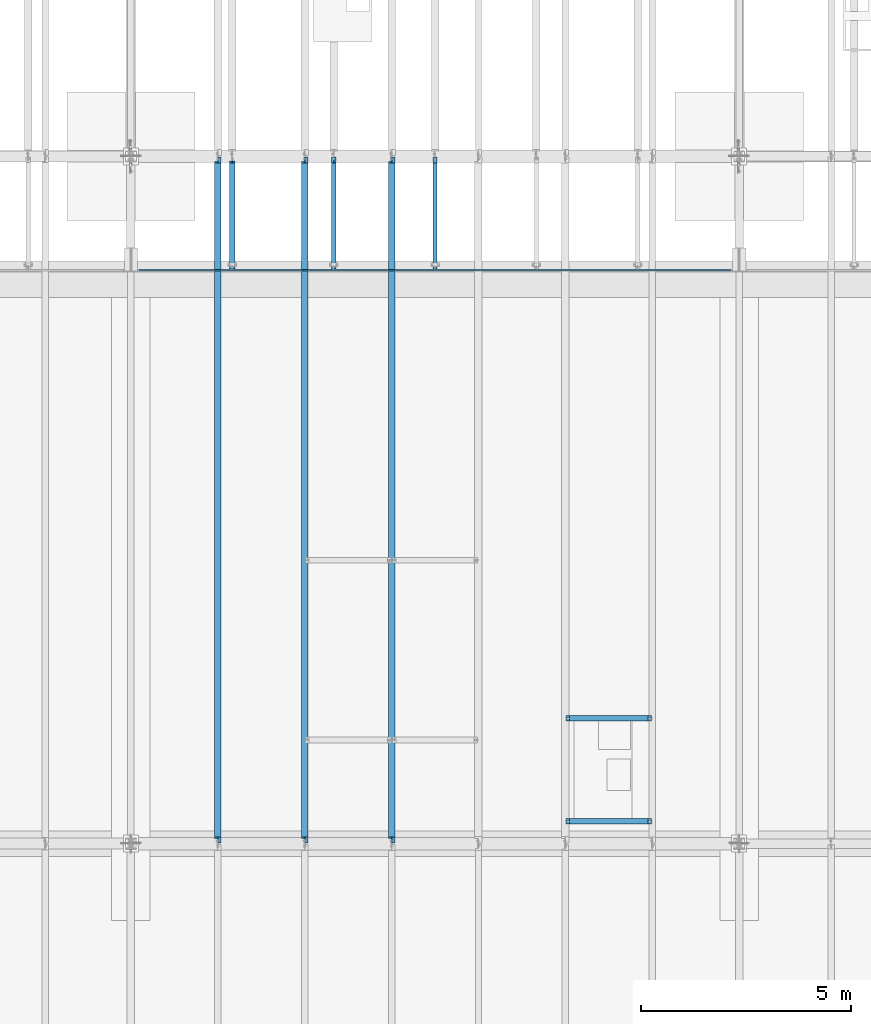
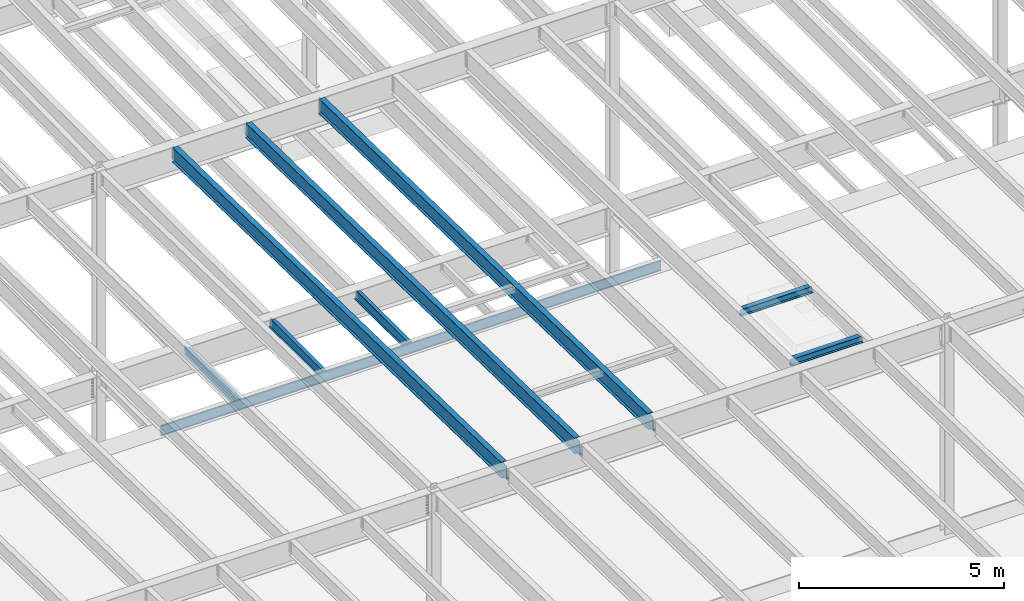
# One storey, part 1102 of 1763: 9 beams, 9 elements without a shape of their own.
"""IFC2X3 building model written with IfcOpenShell, lengths in millimetres."""

import ifcopenshell
import ifcopenshell.guid

model = None  # the IFC model being written
_history = None  # IfcOwnerHistory: only IFC2X3 demands one
_inside = {}  # id of a spatial element -> (the spatial element, [elements in it])
_under = {}  # id of a project, library or spatial element -> (it, [spatial elements below it])
_declared = {}  # id of a project -> (the project, [libraries it declares])
_typed = {}  # id of a type object -> (the type object, [elements of that type])
_made_of = {}  # id of a material, layer set ... -> (it, [elements and type objects made of it])


def new_model(schema):
    """Start an empty IFC model of exactly this schema.

    Asked for "IFC4X3", IfcOpenShell would pick the latest addendum, in which some entities
    have other attributes; the version numbers below select the first issue.
    IFC2X3 requires an IfcOwnerHistory on every rooted entity: one is made here for all.
    """
    global model, _history
    if schema == "IFC4X3":
        model = ifcopenshell.file(schema_version=(4, 3, 0, 0))
    else:
        model = ifcopenshell.file(schema=schema)
    _inside.clear()
    _under.clear()
    _declared.clear()
    _typed.clear()
    _made_of.clear()
    _history = None
    if model.schema == "IFC2X3":
        org = make("IfcOrganization", Name="unknown")
        user = make(
            "IfcPersonAndOrganization",
            ThePerson=make("IfcPerson", FamilyName="unknown"),
            TheOrganization=org,
        )
        app = make(
            "IfcApplication",
            ApplicationDeveloper=org,
            Version="unknown",
            ApplicationFullName="unknown",
            ApplicationIdentifier="unknown",
        )
        _history = make(
            "IfcOwnerHistory",
            OwningUser=user,
            OwningApplication=app,
            ChangeAction="ADDED",
            CreationDate=0,
        )
    return model


def make(cls, **values):
    """One entity of the class cls with the attributes given. An attribute that is None is left unset."""
    return model.create_entity(
        cls, **{name: value for name, value in values.items() if value is not None}
    )


def rooted(cls, **values):
    """An entity with a GlobalId (a new one), such as an element, a storey or a relation."""
    return make(cls, GlobalId=ifcopenshell.guid.new(), OwnerHistory=_history, **values)


def si_unit(unit_type, name, prefix=None):
    """IfcSIUnit, for example si_unit("LENGTHUNIT", "METRE", prefix="MILLI")."""
    return make("IfcSIUnit", UnitType=unit_type, Prefix=prefix, Name=name)


def assignment(units):
    """IfcUnitAssignment: the units of a project."""
    return None if units is None else make("IfcUnitAssignment", Units=units)


def point(xyz):
    """IfcCartesianPoint."""
    return None if xyz is None else make("IfcCartesianPoint", Coordinates=xyz)


def direction(xyz):
    """IfcDirection."""
    return None if xyz is None else make("IfcDirection", DirectionRatios=xyz)


def frame(location, z_axis=None, x_axis=None):
    """IfcAxis2Placement3D, a coordinate frame: its origin and axes. An axis left out is left unset."""
    return make(
        "IfcAxis2Placement3D",
        Location=point(location),
        Axis=direction(z_axis),
        RefDirection=direction(x_axis),
    )


def origin_with_axes():
    """The frame at (0, 0, 0) with the z axis (0, 0, 1) and the x axis (1, 0, 0) written out."""
    return frame((0.0, 0.0, 0.0), z_axis=(0.0, 0.0, 1.0), x_axis=(1.0, 0.0, 0.0))


def place(relative_to, where):
    """IfcLocalPlacement: puts the frame where relative to a parent placement (None: the world)."""
    return make(
        "IfcLocalPlacement", PlacementRelTo=relative_to, RelativePlacement=where
    )


def context(
    kind, dimensions, precision=None, world=None, true_north=None, identifier=None
):
    """IfcGeometricRepresentationContext, for example the 3D "Model" context."""
    return make(
        "IfcGeometricRepresentationContext",
        ContextIdentifier=identifier,
        ContextType=kind,
        CoordinateSpaceDimension=dimensions,
        Precision=precision,
        WorldCoordinateSystem=world,
        TrueNorth=true_north,
    )


def subcontext(parent, identifier, kind, view, scale=None):
    """IfcGeometricRepresentationSubContext, for example "Body" below "Model"."""
    return make(
        "IfcGeometricRepresentationSubContext",
        ContextIdentifier=identifier,
        ContextType=kind,
        ParentContext=parent,
        TargetScale=scale,
        TargetView=view,
    )


def project(units=None, contexts=None):
    """IfcProject with its units and contexts."""
    return rooted(
        "IfcProject",
        Name="project",
        RepresentationContexts=contexts,
        UnitsInContext=assignment(units),
    )


def spatial(cls, under=None, at=None, **own):
    """A site, building, storey or space (cls), placed at a placement, below another one or the project."""
    s = rooted(cls, ObjectPlacement=at, **own)
    if under is not None:
        _under.setdefault(under.id(), (under, []))[1].append(s)
    return s


def faces_of(points, faces, orient=None, outer=None):
    """IfcFace entities. A face is a list of loops; a loop is a list of indices into points, from 0.

    orient and outer hold one flag for each loop. By default every Orientation is true, the
    first loop of a face is its IfcFaceOuterBound and the others are IfcFaceBound.
    """
    made = []
    for i, loops in enumerate(faces):
        bounds = []
        for j, loop in enumerate(loops):
            is_outer = j == 0 if outer is None else outer[i][j]
            bounds.append(
                make(
                    "IfcFaceOuterBound" if is_outer else "IfcFaceBound",
                    Bound=make("IfcPolyLoop", Polygon=[points[k] for k in loop]),
                    Orientation=True if orient is None else orient[i][j],
                )
            )
        made.append(make("IfcFace", Bounds=bounds))
    return made


def faceted_brep(points, faces, orient=None, outer=None, voids=None):
    """IfcFacetedBrep: a solid bounded by flat faces; with voids (closed shells), ...WithVoids."""
    shared = [point(p) for p in points]
    hull = make("IfcClosedShell", CfsFaces=faces_of(shared, faces, orient, outer))
    if voids is None:
        return make("IfcFacetedBrep", Outer=hull)
    return make(
        "IfcFacetedBrepWithVoids",
        Outer=hull,
        Voids=[
            make(cls, CfsFaces=faces_of(shared, fs, o, b)) for cls, fs, o, b in voids
        ],
    )


def shape(context_of_items, identifier, shape_type, items):
    """IfcShapeRepresentation: the items that make up one representation, for example the "Body"."""
    return make(
        "IfcShapeRepresentation",
        ContextOfItems=context_of_items,
        RepresentationIdentifier=identifier,
        RepresentationType=shape_type,
        Items=items,
    )


def material(Name=None, Category=None):
    """IfcMaterial."""
    return make("IfcMaterial", Name=Name, Category=Category)


def made_of(thing, what):
    """Note that an element or type object is made of a material, layer set ...; save() writes the relation."""
    if what is not None:
        _made_of.setdefault(what.id(), (what, []))[1].append(thing)
    return thing


def type_object(cls, material=None, **own):
    """A type object (cls), such as IfcWallType, which elements share."""
    return made_of(rooted(cls, **own), material)


def element(
    cls,
    number,
    at=None,
    inside=None,
    cuts=None,
    type_object=None,
    material=None,
    context=None,
    identifier="Body",
    shape_type=None,
    held_by="IfcProductDefinitionShape",
    body=None,
    shapes=None,
    **own,
):
    """One element of the class cls, such as IfcWall. Its Tag is "e" and its number.

    at: its placement. inside: the storey or other place that contains it. cuts: it is an
    opening in that element (IfcRelVoidsElement). A single representation is given by context,
    identifier, shape_type and body (its items); several are given by shapes. held_by: the class
    of the entity that holds the representations. save() writes the other relations.
    """
    e = rooted(cls, Tag="e%d" % number, ObjectPlacement=at, **own)
    if body is not None:
        shapes = [shape(context, identifier, shape_type, body)]
    if shapes is not None:
        e.Representation = make(held_by, Representations=shapes)
    if inside is not None:
        _inside.setdefault(inside.id(), (inside, []))[1].append(e)
    if cuts is not None:
        rooted(
            "IfcRelVoidsElement", RelatingBuildingElement=cuts, RelatedOpeningElement=e
        )
    if type_object is not None:
        _typed.setdefault(type_object.id(), (type_object, []))[1].append(e)
    return made_of(e, material)


def aggregate(whole, parts):
    """IfcRelAggregates: a whole, such as a stair, and the parts it consists of."""
    return rooted("IfcRelAggregates", RelatingObject=whole, RelatedObjects=parts)


def save(model, path):
    """Write the relations noted so far, then the file.

    IfcRelAggregates (storeys below a building ...), IfcRelContainedInSpatialStructure (elements
    in a storey), IfcRelDefinesByType, IfcRelAssociatesMaterial and IfcRelDeclares: one each for
    every whole, place, type object, material and project.
    """
    for whole, parts in _under.values():
        aggregate(whole, parts)
    for where, things in _inside.values():
        rooted(
            "IfcRelContainedInSpatialStructure",
            RelatedElements=things,
            RelatingStructure=where,
        )
    for kind, things in _typed.values():
        rooted("IfcRelDefinesByType", RelatedObjects=things, RelatingType=kind)
    for what, things in _made_of.values():
        rooted("IfcRelAssociatesMaterial", RelatedObjects=things, RelatingMaterial=what)
    for by, libraries in _declared.values():
        rooted("IfcRelDeclares", RelatingContext=by, RelatedDefinitions=libraries)
    model.write(path)


model = new_model("IFC2X3")

# Units and contexts
model_context = context("Model", 3, precision=1e-05, world=origin_with_axes())
body_context = subcontext(model_context, "Body", "Model", "MODEL_VIEW")
ifc_project = project(units=[si_unit("LENGTHUNIT", "METRE", prefix="MILLI"), si_unit("AREAUNIT", "SQUARE_METRE"), si_unit("VOLUMEUNIT", "CUBIC_METRE"), si_unit("MASSUNIT", "GRAM", prefix="KILO"), si_unit("TIMEUNIT", "SECOND"), si_unit("PLANEANGLEUNIT", "RADIAN"), si_unit("SOLIDANGLEUNIT", "STERADIAN"), si_unit("THERMODYNAMICTEMPERATUREUNIT", "DEGREE_CELSIUS"), si_unit("LUMINOUSINTENSITYUNIT", "LUMEN")], contexts=[model_context])

# Site, building, storey
site_placement = place(None, origin_with_axes())
site = spatial("IfcSite", under=ifc_project, at=site_placement, CompositionType="ELEMENT")
building_placement = place(site_placement, origin_with_axes())
building = spatial("IfcBuilding", under=site, at=building_placement, Name="Undefined", CompositionType="ELEMENT")
storey_placement = place(building_placement, origin_with_axes())
storey = spatial("IfcBuildingStorey", under=building, at=storey_placement, Name="Undefined", CompositionType="ELEMENT", Elevation=0.0)

# Assembly, beam
assembly_1_placement = place(storey_placement, origin_with_axes())
assembly_1 = element("IfcElementAssembly", 1, at=assembly_1_placement, inside=storey, Name="BEAM", AssemblyPlace="NOTDEFINED", PredefinedType="RIGID_FRAME")
ifc_material = material(Name="STEEL/A992")
beam_type_1 = type_object("IfcBeamType", Name="W8X18", PredefinedType="NOTDEFINED")
beam_1_placement = place(assembly_1_placement, frame((-39079.0948629841, 14224.0000000266, 11477.0442138004), z_axis=(0.0, 0.0, 1.0), x_axis=(1.0, 0.0, 0.0)))
beam_1 = element("IfcBeam", 2, at=beam_1_placement, type_object=beam_type_1, material=ifc_material, Name="BEAM", ObjectType="W8X18", context=body_context, shape_type="Brep", body=[
    faceted_brep([(87.2558037621566, -3.17499999999927, 64.8275016696698), (87.2558037621566, 3.17499999999927, 64.8275016696698), (17.4058035714115, 3.17499999999927, 64.8275016696698), (17.4058035714115, -3.17499999999927, 64.8275016696698), (92.115883280203, -3.17499999999927, 65.7942315922573), (92.115883280203, 3.17499999999927, 65.7942315922573), (96.2360597483566, -3.17499999999927, 68.5472454927349), (96.2360597483566, 3.17499999999927, 68.5472454927349), (98.9890736488305, -3.17499999999927, 72.6674219608885), (98.9890736488305, 3.17499999999927, 72.6674219608885), (99.9558035714217, -3.17499999999927, 77.5275014789349), (99.9558035714217, 3.17499999999927, 77.5275014789349), (99.9558035714217, -66.6749999999993, 103.1875), (99.9558035714217, 66.6749999999993, 103.1875), (99.9558035714217, 66.6749999999993, 95.25), (99.9558035714217, 3.17499999999927, 95.25), (99.9558035714217, -3.17499999999927, 95.25), (99.9558035714217, -66.6749999999993, 95.25), (17.4058035714115, -3.17499999999927, -95.25), (17.4058035714115, -66.6749999999993, -95.25), (2047.93169642858, -66.6749999999993, -95.25), (2047.93169642858, -3.17499999999927, -95.25), (17.4058035714115, -66.6749999999993, -103.1875), (2047.93169642858, -66.6749999999993, -103.1875), (17.4058035714115, 66.6749999999993, -103.1875), (2047.93169642858, 66.6749999999993, -103.1875), (17.4058035714115, 66.6749999999993, -95.25), (2047.93169642858, 66.6749999999993, -95.25), (17.4058035714115, 3.17499999999927, -95.25), (2047.93169642858, 3.17499999999927, -95.25), (2047.93169642858, 3.17499999999927, 64.8275016697553), (2047.93169642858, -3.17499999999927, 64.8275016697553), (1978.08169623784, 3.17499999999927, 64.8275016697553), (1978.08169623784, -3.17499999999927, 64.8275016697553), (1973.2216167198, 3.17499999999927, 65.7942315923428), (1973.2216167198, -3.17499999999927, 65.7942315923428), (1969.10144025164, 3.17499999999927, 68.5472454928204), (1969.10144025164, -3.17499999999927, 68.5472454928204), (1966.34842635117, 3.17499999999927, 72.667421960974), (1966.34842635117, -3.17499999999927, 72.667421960974), (1965.38169642858, 3.17499999999927, 77.5275014790204), (1965.38169642858, -3.17499999999927, 77.5275014790204), (1965.38169642858, -66.6749999999993, 103.1875), (1965.38169642858, -66.6749999999993, 95.25), (1965.38169642858, -3.17499999999927, 95.25), (1965.38169642858, 3.17499999999927, 95.25), (1965.38169642858, 66.6749999999993, 95.25), (1965.38169642858, 66.6749999999993, 103.1875)], [[[0, 1, 2, 3]], [[4, 5, 1, 0]], [[6, 7, 5, 4]], [[8, 9, 7, 6]], [[10, 11, 9, 8]], [[12, 13, 14, 15, 11, 10, 16, 17]], [[18, 19, 20, 21]], [[19, 22, 23, 20]], [[22, 24, 25, 23]], [[24, 26, 27, 25]], [[26, 28, 29, 27]], [[21, 20, 23, 25, 27, 29, 30, 31]], [[31, 30, 32, 33]], [[33, 32, 34, 35]], [[35, 34, 36, 37]], [[37, 36, 38, 39]], [[39, 38, 40, 41]], [[42, 43, 44, 41, 40, 45, 46, 47]], [[43, 42, 12, 17]], [[44, 43, 17, 16]], [[8, 6, 4, 0, 3, 18, 21, 31, 33, 35, 37, 39, 41, 44, 16, 10]], [[28, 26, 24, 22, 19, 18, 3, 2]], [[45, 40, 38, 36, 34, 32, 30, 29, 28, 2, 1, 5, 7, 9, 11, 15]], [[46, 45, 15, 14]], [[47, 46, 14, 13]], [[42, 47, 13, 12]]]),
])
aggregate(assembly_1, [beam_1])

assembly_2_placement = place(storey_placement, origin_with_axes())
assembly_2 = element("IfcElementAssembly", 3, at=assembly_2_placement, inside=storey, Name="BEAM", AssemblyPlace="NOTDEFINED", PredefinedType="RIGID_FRAME")
beam_2_placement = place(assembly_2_placement, frame((-39079.0948629841, 16668.7500000266, 11477.0442138004), z_axis=(0.0, 0.0, 1.0), x_axis=(1.0, 0.0, 0.0)))
beam_2 = element("IfcBeam", 4, at=beam_2_placement, type_object=beam_type_1, material=ifc_material, Name="BEAM", ObjectType="W8X18", context=body_context, shape_type="Brep", body=[
    faceted_brep([(17.4058035714115, -3.17499999999927, -95.25), (17.4058035714115, -66.6749999999993, -95.25), (2047.93169642858, -66.6749999999993, -95.25), (2047.93169642858, -3.17499999999927, -95.25), (17.4058035714115, -66.6749999999993, -103.1875), (2047.93169642858, -66.6749999999993, -103.1875), (17.4058035714115, 66.6749999999993, -103.1875), (2047.93169642858, 66.6749999999993, -103.1875), (17.4058035714115, 66.6749999999993, -95.25), (2047.93169642858, 66.6749999999993, -95.25), (1965.38169642858, -66.6749999999993, 103.1875), (1965.38169642858, -66.6749999999993, 95.25), (1965.38169642858, -3.17499999999927, 95.25), (1965.38169642858, -3.17499999999927, 77.5275014790204), (1965.38169642858, 3.17499999999927, 77.5275014790204), (1965.38169642858, 3.17499999999927, 95.25), (1965.38169642858, 66.6749999999993, 95.25), (1965.38169642858, 66.6749999999993, 103.1875), (1966.34842635117, -3.17499999999927, 72.667421960974), (1966.34842635117, 3.17499999999927, 72.667421960974), (1969.10144025164, -3.17499999999927, 68.5472454928204), (1969.10144025164, 3.17499999999927, 68.5472454928204), (1973.2216167198, -3.17499999999927, 65.7942315923428), (1973.2216167198, 3.17499999999927, 65.7942315923428), (1978.08169623784, -3.17499999999927, 64.8275016697553), (1978.08169623784, 3.17499999999927, 64.8275016697553), (1981.05345884623, -3.17499999999927, 64.8275016740627), (1981.05345884623, 3.17499999999927, 64.8275016740627), (1983.54036977155, -3.17499999999927, 63.1658009193525), (1983.54036977155, 3.17499999999927, 63.1658009193525), (1988.4004492896, -3.17499999999927, 62.1990709967649), (1988.4004492896, 3.17499999999927, 62.1990709967649), (2047.93169642858, -3.17499999999927, 62.1990709967649), (2047.93169642858, 3.17499999999927, 62.1990709967649), (2047.93169642858, 3.17499999999927, -95.25), (17.4058035714115, 3.17499999999927, -95.25), (93.703380228435, -3.17499999999927, 56.8144134123104), (93.703380228435, 3.17499999999927, 56.8144134123104), (88.8433007103886, 3.17499999999927, 55.8476834897228), (88.8433007103886, -3.17499999999927, 55.8476834897228), (97.8235566965886, -3.17499999999927, 59.5674273127879), (97.8235566965886, 3.17499999999927, 59.5674273127879), (100.576570597063, -3.17499999999927, 63.6876037809416), (100.576570597063, 3.17499999999927, 63.6876037809416), (101.543300519654, -3.17499999999927, 68.547683298988), (101.543300519654, 3.17499999999927, 68.547683298988), (17.4058035714115, 3.17499999999927, 55.8476834897228), (101.543300519654, 3.17499999999927, 95.25), (101.543300519654, 66.6749999999993, 95.25), (101.543300519654, 66.6749999999993, 103.1875), (101.543300519654, -66.6749999999993, 103.1875), (101.543300519654, -66.6749999999993, 95.25), (101.543300519654, -3.17499999999927, 95.25), (17.4058035714115, -3.17499999999927, 55.8476834897228)], [[[0, 1, 2, 3]], [[1, 4, 5, 2]], [[4, 6, 7, 5]], [[6, 8, 9, 7]], [[10, 11, 12, 13, 14, 15, 16, 17]], [[18, 19, 14, 13]], [[20, 21, 19, 18]], [[22, 23, 21, 20]], [[24, 25, 23, 22]], [[26, 27, 25, 24]], [[28, 29, 27, 26]], [[30, 31, 29, 28]], [[32, 33, 31, 30]], [[3, 2, 5, 7, 9, 34, 33, 32]], [[8, 35, 34, 9]], [[36, 37, 38, 39]], [[40, 41, 37, 36]], [[42, 43, 41, 40]], [[44, 45, 43, 42]], [[15, 14, 19, 21, 23, 25, 27, 29, 31, 33, 34, 35, 46, 38, 37, 41, 43, 45, 47]], [[16, 15, 47, 48]], [[17, 16, 48, 49]], [[10, 17, 49, 50]], [[11, 10, 50, 51]], [[12, 11, 51, 52]], [[50, 49, 48, 47, 45, 44, 52, 51]], [[42, 40, 36, 39, 53, 0, 3, 32, 30, 28, 26, 24, 22, 20, 18, 13, 12, 52, 44]], [[35, 8, 6, 4, 1, 0, 53, 46]], [[39, 38, 46, 53]]]),
])
aggregate(assembly_2, [beam_2])

assembly_3_placement = place(storey_placement, origin_with_axes())
assembly_3 = element("IfcElementAssembly", 5, at=assembly_3_placement, inside=storey, Name="BEAM", AssemblyPlace="NOTDEFINED", PredefinedType="RIGID_FRAME")
beam_3_placement = place(assembly_3_placement, frame((-46993.6706070317, 27279.6, 5091.1125), z_axis=(0.0, 0.0, 1.0), x_axis=(0.0, 1.0, 0.0)))
beam_3 = element("IfcBeam", 6, at=beam_3_placement, type_object=beam_type_1, material=ifc_material, Name="BEAM", ObjectType="W8X18", context=body_context, shape_type="Brep", body=[
    faceted_brep([(2634.45622848038, 3.4751352359599, -95.25), (2634.45622848058, 3.47487102042214, -103.1875), (2634.45618089067, 66.6750000000029, -103.1875), (2634.45618089067, 66.6750000000029, -95.25), (2723.35625, 3.47520217805868, -95.25), (2723.35625, 3.47493796249182, -103.1875), (63.5000000000036, 3.17500000000291, 95.25), (63.5000000000036, 66.6750000000029, 95.25), (2583.65625, 66.6750000000029, 95.25), (2583.65625, 3.17500000000291, 95.25), (63.5000000000036, -66.6750000000029, -103.1875), (63.5000000000036, -66.6750000000029, -95.25), (63.5000000000036, -3.17500000000291, -95.25), (63.5000000000036, -3.17500000000291, 95.25), (63.5000000000036, -66.6750000000029, 95.25), (63.5000000000036, -66.6750000000029, 103.1875), (63.5000000000036, 66.6750000000029, 103.1875), (63.5000000000036, 3.17500000000291, -95.25), (63.5000000000036, 66.6750000000029, -95.25), (63.5000000000036, 66.6750000000029, -103.1875), (2634.45624623523, -66.6750000000029, -103.1875), (2634.45624623523, -66.6750000000029, -95.25), (2634.45619864566, -3.47513512033038, -103.1875), (2634.45619864546, -3.47487090479262, -95.25), (2723.35625, -3.47480396302853, -95.25), (2723.35625, -3.47506817859539, -103.1875), (2723.35625, -3.17500000000291, -95.25), (2591.49617029122, -3.17500000000291, 72.1442316010543), (2587.37599382306, -3.17500000000291, 74.8972455015328), (2584.62297992258, -3.17500000000291, 79.0174219696864), (2583.65625, -3.17500000000291, 83.8775014877319), (2583.65625, -3.17500000000291, 95.25), (2723.35625, -3.17500000000291, 71.1775016784668), (2596.35624980926, -3.17500000000291, 71.1775016784668), (2583.65625, -66.6750000000029, 95.25), (2583.65625, -66.6750000000029, 103.1875), (2583.65625, 66.6750000000029, 103.1875), (2583.65625, 3.17500000000291, 83.8775014877319), (2584.62297992258, 3.17500000000291, 79.0174219696864), (2587.37599382306, 3.17500000000291, 74.8972455015328), (2591.49617029122, 3.17500000000291, 72.1442316010543), (2596.35624980926, 3.17500000000291, 71.1775016784668), (2723.35625, 3.17500000000291, 71.1775016784668), (2723.35625, 3.17500000000291, -95.25)], [[[0, 1, 2, 3]], [[4, 5, 1, 0]], [[6, 7, 8, 9]], [[10, 11, 12, 13, 14, 15, 16, 7, 6, 17, 18, 19]], [[11, 10, 20, 21]], [[21, 20, 22, 23]], [[24, 23, 22, 25]], [[26, 12, 11, 21, 23, 24]], [[27, 28, 29, 30, 31, 13, 12, 26, 32, 33]], [[14, 13, 31, 34]], [[15, 14, 34, 35]], [[16, 15, 35, 36]], [[7, 16, 36, 8]], [[35, 34, 31, 30, 37, 9, 8, 36]], [[29, 38, 37, 30]], [[28, 39, 38, 29]], [[27, 40, 39, 28]], [[33, 41, 40, 27]], [[32, 42, 41, 33]], [[43, 17, 6, 9, 37, 38, 39, 40, 41, 42]], [[3, 18, 17, 43, 4, 0]], [[19, 18, 3, 2]], [[25, 22, 20, 10, 19, 2, 1, 5]], [[43, 42, 32, 26, 24, 25, 5, 4]]]),
])
aggregate(assembly_3, [beam_3])

assembly_4_placement = place(storey_placement, origin_with_axes())
assembly_4 = element("IfcElementAssembly", 7, at=assembly_4_placement, inside=storey, Name="BEAM", AssemblyPlace="NOTDEFINED", PredefinedType="RIGID_FRAME")
beam_type_2 = type_object("IfcBeamType", Name="W12X16", PredefinedType="NOTDEFINED")
beam_4_placement = place(assembly_4_placement, frame((-42176.1372736983, 27279.6, 5041.9), z_axis=(0.0, 0.0, 1.0), x_axis=(0.0, 1.0, 0.0)))
beam_4 = element("IfcBeam", 8, at=beam_4_placement, type_object=beam_type_2, material=ifc_material, Name="BEAM", ObjectType="W12X16", context=body_context, shape_type="Brep", body=[
    faceted_brep([(63.5000000000036, -3.17499999999927, -146.05), (63.5000000000036, -50.7999999999993, -146.05), (2723.35625, -50.8000000000029, -146.05), (2723.35625, -3.17500000000291, -146.05), (63.5000000000036, -50.7999999999993, -152.4), (2723.35625, -50.8000000000029, -152.4), (63.5000000000036, 50.7999999999993, -152.4), (2723.35625, 50.8000000000029, -152.4), (63.5000000000036, 50.7999999999993, -146.05), (63.5000000000036, 3.17499999999927, -146.05), (2723.35625, 3.17500000000291, -146.05), (2723.35625, 50.8000000000029, -146.05), (2723.35625, 3.17500000000291, 120.390001678466), (2723.35625, -3.17500000000291, 120.390001678466), (63.5000000000036, -3.17499999999927, 146.05), (63.5000000000036, -50.7999999999993, 146.05), (63.5000000000036, -50.7999999999993, 152.4), (63.5000000000036, 50.7999999999993, 152.4), (63.5000000000036, 50.7999999999993, 146.05), (63.5000000000036, 3.17499999999927, 146.05), (2583.65625, 50.8000000000029, 146.05), (2583.65625, 3.17500000000291, 146.05), (2583.65625, 3.17500000000291, 133.090001487732), (2584.62297992259, 3.17500000000291, 128.229921969686), (2587.37599382307, 3.17500000000291, 124.109745501532), (2591.49617029122, 3.17500000000291, 121.356731601054), (2596.35624980927, 3.17500000000291, 120.390001678466), (2584.62297992259, -3.17500000000291, 128.229921969686), (2583.65625, -3.17500000000291, 133.090001487732), (2587.37599382307, -3.17500000000291, 124.109745501532), (2591.49617029122, -3.17500000000291, 121.356731601054), (2596.35624980927, -3.17500000000291, 120.390001678466), (2583.65625, -3.17500000000291, 146.05), (2583.65625, -50.8000000000029, 146.05), (2583.65625, -50.8000000000029, 152.4), (2583.65625, 50.8000000000029, 152.4)], [[[0, 1, 2, 3]], [[1, 4, 5, 2]], [[4, 6, 7, 5]], [[8, 9, 10, 11]], [[3, 2, 5, 7, 11, 10, 12, 13]], [[6, 8, 11, 7]], [[4, 1, 0, 14, 15, 16, 17, 18, 19, 9, 8, 6]], [[19, 18, 20, 21]], [[10, 9, 19, 21, 22, 23, 24, 25, 26, 12]], [[27, 23, 22, 28]], [[29, 24, 23, 27]], [[30, 25, 24, 29]], [[31, 26, 25, 30]], [[13, 12, 26, 31]], [[30, 29, 27, 28, 32, 14, 0, 3, 13, 31]], [[15, 14, 32, 33]], [[16, 15, 33, 34]], [[17, 16, 34, 35]], [[18, 17, 35, 20]], [[34, 33, 32, 28, 22, 21, 20, 35]]]),
])
aggregate(assembly_4, [beam_4])

assembly_5_placement = place(storey_placement, origin_with_axes())
assembly_5 = element("IfcElementAssembly", 9, at=assembly_5_placement, inside=storey, Name="BEAM", AssemblyPlace="NOTDEFINED", PredefinedType="RIGID_FRAME")
beam_5_placement = place(assembly_5_placement, frame((-44584.903940365, 27279.6, 5041.9), z_axis=(0.0, 0.0, 1.0), x_axis=(0.0, 1.0, 0.0)))
beam_5 = element("IfcBeam", 10, at=beam_5_placement, type_object=beam_type_2, material=ifc_material, Name="BEAM", ObjectType="W12X16", context=body_context, shape_type="Brep", body=[
    faceted_brep([(63.5000000000036, -3.17499999999927, -146.05), (63.5000000000036, -50.7999999999993, -146.05), (2723.35625, -50.8000000000029, -146.05), (2723.35625, -3.17500000000291, -146.05), (63.5000000000036, -50.7999999999993, -152.4), (2723.35625, -50.8000000000029, -152.4), (63.5000000000036, 50.7999999999993, -152.4), (2723.35625, 50.8000000000029, -152.4), (63.5000000000036, 50.7999999999993, -146.05), (63.5000000000036, 3.17499999999927, -146.05), (2723.35625, 3.17500000000291, -146.05), (2723.35625, 50.8000000000029, -146.05), (2723.35625, 3.17500000000291, 120.390001678466), (2723.35625, -3.17500000000291, 120.390001678466), (63.5000000000036, -3.17499999999927, 146.05), (63.5000000000036, -50.7999999999993, 146.05), (63.5000000000036, -50.7999999999993, 152.4), (63.5000000000036, 50.7999999999993, 152.4), (63.5000000000036, 50.7999999999993, 146.05), (63.5000000000036, 3.17499999999927, 146.05), (2583.65625, 50.8000000000029, 146.05), (2583.65625, 3.17500000000291, 146.05), (2583.65625, 3.17500000000291, 133.090001487732), (2584.62297992259, 3.17500000000291, 128.229921969686), (2587.37599382307, 3.17500000000291, 124.109745501532), (2591.49617029122, 3.17500000000291, 121.356731601054), (2596.35624980927, 3.17500000000291, 120.390001678466), (2584.62297992259, -3.17500000000291, 128.229921969686), (2583.65625, -3.17500000000291, 133.090001487732), (2587.37599382307, -3.17500000000291, 124.109745501532), (2591.49617029122, -3.17500000000291, 121.356731601054), (2596.35624980927, -3.17500000000291, 120.390001678466), (2583.65625, -3.17500000000291, 146.05), (2583.65625, -50.8000000000029, 146.05), (2583.65625, -50.8000000000029, 152.4), (2583.65625, 50.8000000000029, 152.4)], [[[0, 1, 2, 3]], [[1, 4, 5, 2]], [[4, 6, 7, 5]], [[8, 9, 10, 11]], [[3, 2, 5, 7, 11, 10, 12, 13]], [[6, 8, 11, 7]], [[4, 1, 0, 14, 15, 16, 17, 18, 19, 9, 8, 6]], [[19, 18, 20, 21]], [[10, 9, 19, 21, 22, 23, 24, 25, 26, 12]], [[27, 23, 22, 28]], [[29, 24, 23, 27]], [[30, 25, 24, 29]], [[31, 26, 25, 30]], [[13, 12, 26, 31]], [[30, 29, 27, 28, 32, 14, 0, 3, 13, 31]], [[15, 14, 32, 33]], [[16, 15, 33, 34]], [[17, 16, 34, 35]], [[18, 17, 35, 20]], [[34, 33, 32, 28, 22, 21, 20, 35]]]),
])
aggregate(assembly_5, [beam_5])

assembly_6_placement = place(storey_placement, origin_with_axes())
assembly_6 = element("IfcElementAssembly", 11, at=assembly_6_placement, inside=storey, Name="BEAM", AssemblyPlace="NOTDEFINED", PredefinedType="RIGID_FRAME")
beam_type_3 = type_object("IfcBeamType", Name="W18X40", PredefinedType="NOTDEFINED")
beam_6_placement = place(assembly_6_placement, frame((-43208.4658451269, 13685.8551307139, 11404.7768219843), z_axis=(0.0, 0.0209013539966291, 0.999781542838788), x_axis=(0.0, 0.999781542776098, -0.0209013569953182)))
beam_6 = element("IfcBeam", 12, at=beam_6_placement, type_object=beam_type_3, material=ifc_material, Name="BEAM", ObjectType="W18X40", context=body_context, shape_type="Brep", body=[
    faceted_brep([(16224.7811528147, 3.96875, -214.312499990414), (16224.7811528147, 3.96875, -227.012499990411), (16224.7811528147, 76.1999999999971, -227.012499990411), (16224.7811528147, 76.1999999999971, -214.312499990414), (16325.4123927121, 3.96875, -227.012499990353), (16325.1468877506, 3.96875, -214.312499990354), (29.0743924101943, -3.96875, -214.31250000018), (29.0743924101943, -76.1999999999971, -214.31250000018), (16325.1468877506, -76.1999999999971, -214.312499990354), (16325.1468877506, -3.96875, -214.312499990354), (163.327262094397, -3.96875, 190.142421969791), (160.574248193921, -3.96875, 186.022245501637), (156.454071725771, -3.96875, 183.269231601158), (151.593992207727, -3.96875, 182.302501678567), (20.7827897637508, -3.96875, 182.30250167849), (16316.7225317559, -3.96875, 188.65250182258), (16188.8431415337, -3.96875, 188.652501822504), (16183.9830620156, -3.96875, 189.619231745088), (16179.8628855475, -3.96875, 192.372245645562), (16177.109871647, -3.96875, 196.492422113712), (16176.1431417244, -3.96875, 201.352501631756), (16176.1431417244, -3.96875, 214.312500009495), (164.29399201697, -3.96875, 214.312500000067), (164.293992016979, -3.96875, 195.002501487832), (164.293992016979, 3.96875, 195.002501487832), (163.327262094397, 3.96875, 190.142421969791), (160.574248193921, 3.96875, 186.022245501637), (156.454071725771, 3.96875, 183.269231601158), (151.593992207727, 3.96875, 182.302501678567), (20.7827897637508, 3.96875, 182.30250167849), (132.543992672528, 76.1999999999971, -214.312499999889), (132.543992672539, 76.1999999999971, -227.012499999888), (132.544002095599, 4.26882839031896, -227.012499999888), (132.544002095614, 4.26866853534011, -214.312499999889), (29.339897632873, 4.26882972748717, -227.01250000019), (29.0743924101943, 4.26863241521642, -214.31250000018), (29.339897632873, -76.1999999999971, -227.01250000019), (29.0743924101943, 3.96875, -214.31250000018), (16325.412392986, -76.1999999999971, -227.012499990351), (16324.7486296237, 3.96875, -195.26249999026), (16316.7225317559, 3.96875, 188.65250182258), (16188.8431415337, 3.96875, 188.652501822504), (16183.9830620156, 3.96875, 189.619231745088), (16179.8628855475, 3.96875, 192.372245645562), (16177.109871647, 3.96875, 196.492422113712), (16176.1431417244, 3.96875, 201.352501631756), (16176.1431417244, -76.1999999999971, 227.012500009492), (16176.1431417244, -76.1999999999971, 214.312500009495), (16176.1431417244, 3.96875, 214.312500009495), (16176.1431417244, 76.1999999999971, 214.312500009495), (16176.1431417244, 76.1999999999971, 227.012500009492), (164.29399201697, 3.96875, 214.312500000067), (164.29399201697, 76.1999999999971, 214.312500000067), (164.293992016963, 76.1999999999971, 227.012500000064), (164.293992016963, -76.1999999999971, 227.012500000064), (164.29399201697, -76.1999999999971, 214.312500000067)], [[[0, 1, 2, 3]], [[4, 1, 0, 5]], [[6, 7, 8, 9]], [[10, 11, 12, 13, 14, 6, 9, 15, 16, 17, 18, 19, 20, 21, 22, 23]], [[23, 24, 25, 10]], [[10, 25, 26, 11]], [[11, 26, 27, 12]], [[12, 27, 28, 13]], [[13, 28, 29, 14]], [[30, 31, 32, 33]], [[33, 32, 34, 35]], [[36, 7, 6, 14, 29, 37, 35, 34]], [[7, 36, 38, 8]], [[39, 40, 15, 9, 8, 38, 4, 5]], [[15, 40, 41, 16]], [[16, 41, 42, 17]], [[17, 42, 43, 18]], [[18, 43, 44, 19]], [[19, 44, 45, 20]], [[46, 47, 21, 20, 45, 48, 49, 50]], [[49, 48, 51, 52]], [[50, 49, 52, 53]], [[46, 50, 53, 54]], [[47, 46, 54, 55]], [[21, 47, 55, 22]], [[54, 53, 52, 51, 24, 23, 22, 55]], [[48, 45, 44, 43, 42, 41, 40, 39, 5, 0, 37, 29, 28, 27, 26, 25, 24, 51]], [[30, 33, 35, 37, 0, 3]], [[31, 30, 3, 2]], [[38, 36, 34, 32, 31, 2, 1, 4]]]),
])
aggregate(assembly_6, [beam_6])

assembly_7_placement = place(storey_placement, origin_with_axes())
assembly_7 = element("IfcElementAssembly", 13, at=assembly_7_placement, inside=storey, Name="BEAM", AssemblyPlace="NOTDEFINED", PredefinedType="RIGID_FRAME")
beam_7_placement = place(assembly_7_placement, frame((-45273.1229879841, 13685.8550714413, 11404.7768219843), z_axis=(0.0, 0.0209013539966291, 0.999781542838788), x_axis=(0.0, 0.999781542776098, -0.0209013569953182)))
beam_7 = element("IfcBeam", 14, at=beam_7_placement, type_object=beam_type_3, material=ifc_material, Name="BEAM", ObjectType="W18X40", context=body_context, shape_type="Brep", body=[
    faceted_brep([(132.544061381936, 4.26866853682441, -214.312499999887), (132.544061381923, 4.26882839180325, -227.012499999888), (29.339957385273, 4.26881487214268, -227.012499999948), (29.0744521498946, 4.26865498234838, -214.312499999949), (132.54405195883, 76.1999999999971, -214.312499999889), (132.544051958839, 76.1999999999971, -227.012499999886), (164.294051302735, -3.96875, 195.002501487843), (164.294051302735, 3.96875, 195.002501487843), (163.327321380151, 3.96875, 190.142421969796), (163.327321380151, -3.96875, 190.142421969796), (160.574307479677, 3.96875, 186.022245501646), (160.574307479677, -3.96875, 186.022245501646), (156.454131011527, 3.96875, 183.269231601167), (156.454131011527, -3.96875, 183.269231601167), (151.594051493483, 3.96875, 182.302501678576), (151.594051493483, -3.96875, 182.302501678576), (20.7828490495212, 3.96875, 182.3025016785), (20.7828490495212, -3.96875, 182.3025016785), (29.0744516959673, -3.96875, -214.31250000018), (16325.1469467623, -3.96875, -214.312499990352), (16316.9880962768, -3.96875, 175.952501822545), (16188.8432008193, -3.96875, 175.952501822472), (16183.9831213012, -3.96875, 176.919231745054), (16179.862944833, -3.96875, 179.67224564553), (16177.1099309326, -3.96875, 183.792422113678), (16176.14320101, -3.96875, 188.652501631721), (16176.14320101, -3.96875, 214.312500009495), (164.294051302724, -3.96875, 214.312500000067), (29.0744521498946, -76.1999999999971, -214.312499999949), (16325.1469467623, -76.1999999999971, -214.312499990352), (29.339957385273, -76.1999999999971, -227.012499999948), (16325.4124519977, -76.1999999999971, -227.012499990351), (16225.3785988799, 76.1999999999971, -227.012499990409), (16225.1130936445, 76.1999999999971, -214.312499990414), (16225.1130936445, 5.51250000000437, -214.312499990414), (16225.3785988799, 5.51250000000437, -227.012499990409), (16325.4124519977, 5.51250000000437, -227.012499990351), (16325.1469467623, 5.51250000000437, -214.312499990352), (16325.1469467623, 3.96875, -214.312499990352), (16316.9880962768, 3.96875, 175.952501822545), (16188.8432008193, 3.96875, 175.952501822472), (16183.9831213012, 3.96875, 176.919231745054), (16179.862944833, 3.96875, 179.67224564553), (16177.1099309326, 3.96875, 183.792422113678), (16176.14320101, 3.96875, 188.652501631721), (16176.1432010099, -76.1999999999971, 227.012500009494), (16176.14320101, -76.1999999999971, 214.312500009495), (16176.14320101, 3.96875, 214.312500009495), (16176.14320101, 76.1999999999971, 214.312500009495), (16176.1432010099, 76.1999999999971, 227.012500009494), (164.294051302724, 3.96875, 214.312500000067), (164.294051302724, 76.1999999999971, 214.312500000067), (164.294051302717, 76.1999999999971, 227.012500000064), (164.294051302717, -76.1999999999971, 227.012500000064), (164.294051302724, -76.1999999999971, 214.312500000067), (29.0744516959673, 3.96875, -214.31250000018)], [[[0, 1, 2, 3]], [[4, 5, 1, 0]], [[6, 7, 8, 9]], [[9, 8, 10, 11]], [[11, 10, 12, 13]], [[13, 12, 14, 15]], [[15, 14, 16, 17]], [[9, 11, 13, 15, 17, 18, 19, 20, 21, 22, 23, 24, 25, 26, 27, 6]], [[18, 28, 29, 19]], [[28, 30, 31, 29]], [[32, 33, 34, 35]], [[36, 35, 34, 37]], [[19, 29, 31, 36, 37, 38, 39, 20]], [[20, 39, 40, 21]], [[21, 40, 41, 22]], [[22, 41, 42, 23]], [[23, 42, 43, 24]], [[24, 43, 44, 25]], [[45, 46, 26, 25, 44, 47, 48, 49]], [[48, 47, 50, 51]], [[49, 48, 51, 52]], [[45, 49, 52, 53]], [[46, 45, 53, 54]], [[26, 46, 54, 27]], [[53, 52, 51, 50, 7, 6, 27, 54]], [[47, 44, 43, 42, 41, 40, 39, 38, 55, 16, 14, 12, 10, 8, 7, 50]], [[30, 28, 18, 17, 16, 55, 3, 2]], [[32, 35, 36, 31, 30, 2, 1, 5]], [[33, 32, 5, 4]], [[55, 38, 37, 34, 33, 4, 0, 3]]]),
])
aggregate(assembly_7, [beam_7])

assembly_8_placement = place(storey_placement, origin_with_axes())
assembly_8 = element("IfcElementAssembly", 15, at=assembly_8_placement, inside=storey, Name="BEAM", AssemblyPlace="NOTDEFINED", PredefinedType="RIGID_FRAME")
beam_8_placement = place(assembly_8_placement, frame((-47337.7801308412, 13685.855130714, 11404.7768219843), z_axis=(0.0, 0.0209013539966291, 0.999781542838788), x_axis=(0.0, 0.999781542776098, -0.0209013569953182)))
beam_8 = element("IfcBeam", 16, at=beam_8_placement, type_object=beam_type_3, material=ifc_material, Name="BEAM", ObjectType="W18X40", context=body_context, shape_type="Brep", body=[
    faceted_brep([(132.544002095614, 4.26866853534011, -214.312499999889), (132.544002095599, 4.26882839031896, -227.012499999888), (29.339897632873, 4.26882972748717, -227.01250000019), (29.0743924101943, 4.26863241521642, -214.31250000018), (132.543992672528, 76.1999999999971, -214.312499999889), (132.543992672539, 76.1999999999971, -227.012499999888), (164.293992016979, -3.96875, 195.002501487832), (164.293992016979, 3.96875, 195.002501487832), (163.327262094397, 3.96875, 190.142421969791), (163.327262094397, -3.96875, 190.142421969791), (160.574248193921, 3.96875, 186.022245501637), (160.574248193921, -3.96875, 186.022245501637), (156.454071725771, 3.96875, 183.269231601158), (156.454071725771, -3.96875, 183.269231601158), (151.593992207727, 3.96875, 182.302501678567), (151.593992207727, -3.96875, 182.302501678567), (20.7827897637508, 3.96875, 182.30250167849), (20.7827897637508, -3.96875, 182.30250167849), (29.0743924101943, -3.96875, -214.31250000018), (16325.1468877506, -3.96875, -214.312499990354), (16316.8552846474, -3.96875, 182.302501822591), (16187.3164867041, -3.96875, 182.302501822514), (16182.456407186, -3.96875, 183.269231745098), (16178.3362307179, -3.96875, 186.022245645572), (16175.5832168174, -3.96875, 190.142422113722), (16174.6164868948, -3.96875, 195.002501631765), (16174.6164868948, -3.96875, 214.312500009495), (164.29399201697, -3.96875, 214.312500000067), (29.0743924101943, -76.1999999999971, -214.31250000018), (16325.1468877506, -76.1999999999971, -214.312499990354), (29.339897632873, -76.1999999999971, -227.01250000019), (16325.412392986, -76.1999999999971, -227.012499990351), (16225.4164838328, 4.26882845565706, -214.312499990412), (16225.4164838328, 4.26866860519658, -227.012499990411), (16225.4164773588, 76.1999999999971, -227.012499990409), (16225.4164773587, 76.1999999999971, -214.312499990414), (16325.412392986, 4.2686776052069, -227.012499990351), (16325.1468877506, 4.26883743175858, -214.312499990354), (16325.1468877506, 3.96875, -214.312499990354), (16316.8552846474, 3.96875, 182.302501822591), (16187.3164867041, 3.96875, 182.302501822514), (16182.456407186, 3.96875, 183.269231745098), (16178.3362307179, 3.96875, 186.022245645572), (16175.5832168174, 3.96875, 190.142422113722), (16174.6164868948, 3.96875, 195.002501631765), (16174.6164868948, -76.1999999999971, 227.01250000949), (16174.6164868948, -76.1999999999971, 214.312500009495), (16174.6164868948, 3.96875, 214.312500009495), (16174.6164868948, 76.1999999999971, 214.312500009495), (16174.6164868948, 76.1999999999971, 227.01250000949), (164.29399201697, 3.96875, 214.312500000067), (164.29399201697, 76.1999999999971, 214.312500000067), (164.293992016963, 76.1999999999971, 227.012500000064), (164.293992016963, -76.1999999999971, 227.012500000064), (164.29399201697, -76.1999999999971, 214.312500000067), (29.0743924101943, 3.96875, -214.31250000018)], [[[0, 1, 2, 3]], [[4, 5, 1, 0]], [[6, 7, 8, 9]], [[9, 8, 10, 11]], [[11, 10, 12, 13]], [[13, 12, 14, 15]], [[15, 14, 16, 17]], [[9, 11, 13, 15, 17, 18, 19, 20, 21, 22, 23, 24, 25, 26, 27, 6]], [[18, 28, 29, 19]], [[28, 30, 31, 29]], [[32, 33, 34, 35]], [[36, 33, 32, 37]], [[38, 39, 20, 19, 29, 31, 36, 37]], [[20, 39, 40, 21]], [[21, 40, 41, 22]], [[22, 41, 42, 23]], [[23, 42, 43, 24]], [[24, 43, 44, 25]], [[45, 46, 26, 25, 44, 47, 48, 49]], [[48, 47, 50, 51]], [[49, 48, 51, 52]], [[45, 49, 52, 53]], [[46, 45, 53, 54]], [[26, 46, 54, 27]], [[53, 52, 51, 50, 7, 6, 27, 54]], [[47, 44, 43, 42, 41, 40, 39, 38, 55, 16, 14, 12, 10, 8, 7, 50]], [[30, 28, 18, 17, 16, 55, 3, 2]], [[34, 33, 36, 31, 30, 2, 1, 5]], [[35, 34, 5, 4]], [[55, 38, 37, 32, 35, 4, 0, 3]]]),
])
aggregate(assembly_8, [beam_8])

assembly_9_placement = place(storey_placement, origin_with_axes())
assembly_9 = element("IfcElementAssembly", 17, at=assembly_9_placement, inside=storey, Name="BEAM", AssemblyPlace="NOTDEFINED", PredefinedType="RIGID_FRAME")
beam_type_4 = type_object("IfcBeamType", Name="MC12X10.6", PredefinedType="NOTDEFINED")
beam_9_placement = place(assembly_9_placement, frame((-49219.8747736984, 27311.35, 5041.9), z_axis=(0.0, 0.0, 1.0), x_axis=(1.0, 0.0, 0.0)))
beam_9 = element("IfcBeam", 18, at=beam_9_placement, type_object=beam_type_4, material=ifc_material, Name="BEAM", ObjectType="MC12X10.6", context=body_context, shape_type="Brep", body=[
    faceted_brep([(0.0, 19.0499999999993, -152.4), (0.0, 19.0499999999993, 152.4), (14087.475, 19.0499999999993, 152.4), (14087.475, 19.0499999999993, -152.4), (0.0, -19.0499999999993, 152.4), (14087.475, -19.0499999999993, 152.4), (0.0, -19.0499999999993, 144.841595), (14087.475, -19.0499999999993, 144.841595), (0.0, 14.2874999999985, 144.17817875), (14087.475, 14.2874999999985, 144.17817875), (0.0, 14.2874999999985, -144.17817875), (14087.475, 14.2874999999985, -144.17817875), (0.0, -19.0499999999993, -144.841595), (14087.475, -19.0499999999993, -144.841595), (0.0, -19.0499999999993, -152.4), (14087.475, -19.0499999999993, -152.4)], [[[0, 1, 2, 3]], [[1, 4, 5, 2]], [[4, 6, 7, 5]], [[6, 8, 9, 7]], [[8, 10, 11, 9]], [[10, 12, 13, 11]], [[12, 14, 15, 13]], [[14, 0, 3, 15]], [[5, 7, 9, 11, 13, 15, 3, 2]], [[14, 12, 10, 8, 6, 4, 1, 0]]]),
])
aggregate(assembly_9, [beam_9])

save(model, "model.ifc")
